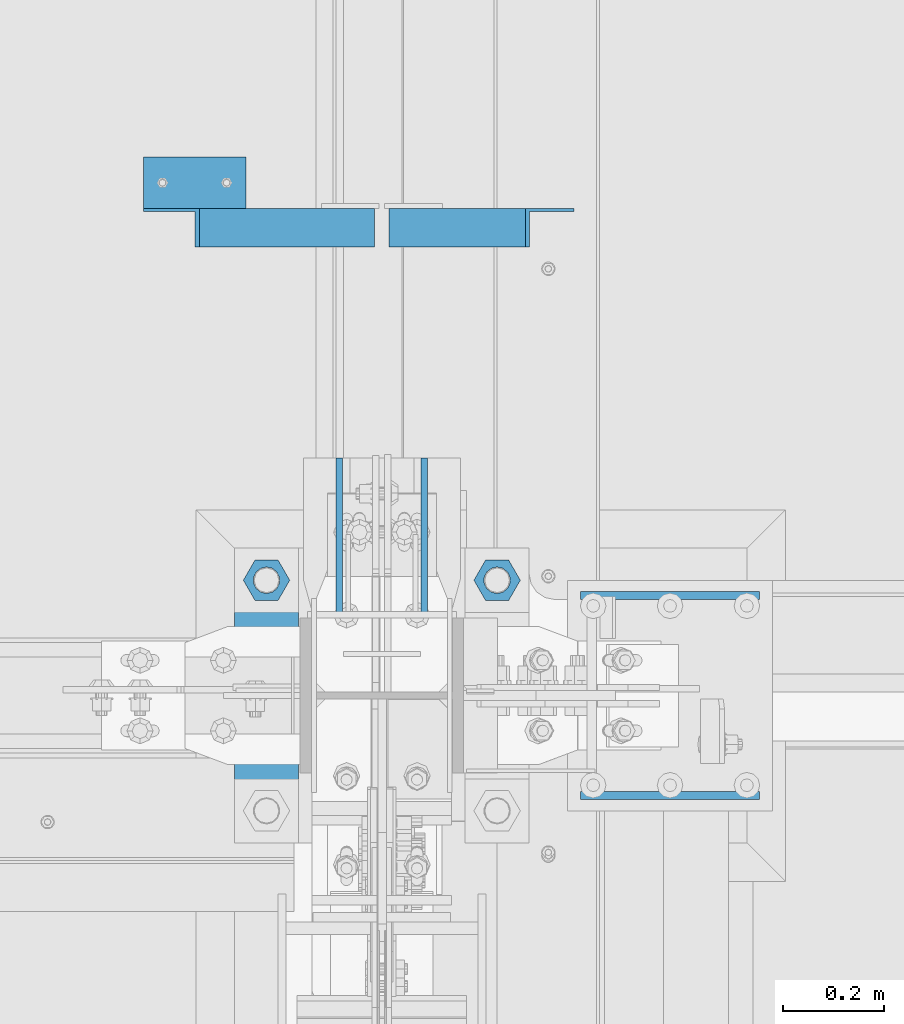
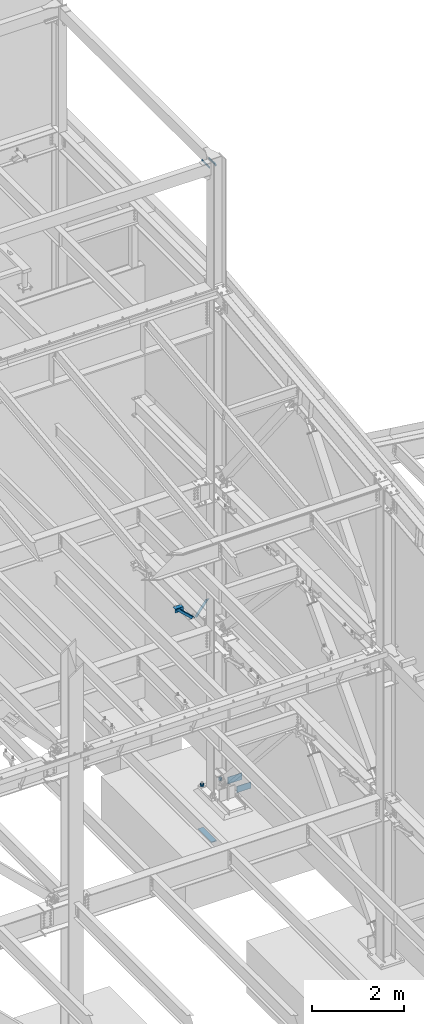
# One storey, part 899 of 1179: 8 beams, 2 members, 7 elements without a shape of their own.
"""IFC2X3 building model written with IfcOpenShell, lengths in millimetres."""

from ifc_helpers import new_model, si_unit, frame, origin_with_axes, place, context, subcontext, project, spatial, faceted_brep, material, type_object, element, aggregate, save


model = new_model("IFC2X3")

# Units and contexts
model_context = context("Model", 3, precision=1e-05, world=origin_with_axes())
body_context = subcontext(model_context, "Body", "Model", "MODEL_VIEW")
ifc_project = project(units=[si_unit("LENGTHUNIT", "METRE", prefix="MILLI"), si_unit("AREAUNIT", "SQUARE_METRE"), si_unit("VOLUMEUNIT", "CUBIC_METRE"), si_unit("MASSUNIT", "GRAM", prefix="KILO"), si_unit("TIMEUNIT", "SECOND"), si_unit("PLANEANGLEUNIT", "RADIAN"), si_unit("SOLIDANGLEUNIT", "STERADIAN"), si_unit("THERMODYNAMICTEMPERATUREUNIT", "DEGREE_CELSIUS"), si_unit("LUMINOUSINTENSITYUNIT", "LUMEN")], contexts=[model_context])

# Site, building, storey
site_placement = place(None, origin_with_axes())
site = spatial("IfcSite", under=ifc_project, at=site_placement, CompositionType="ELEMENT")
building_placement = place(site_placement, origin_with_axes())
building = spatial("IfcBuilding", under=site, at=building_placement, Name="Undefined", CompositionType="ELEMENT")
storey_placement = place(building_placement, origin_with_axes())
storey = spatial("IfcBuildingStorey", under=building, at=storey_placement, Name="Undefined", CompositionType="ELEMENT", Elevation=0.0)

# Assembly, member
assembly_1_placement = place(storey_placement, origin_with_axes())
assembly_1 = element("IfcElementAssembly", 1, at=assembly_1_placement, inside=storey, Name="ANGLE", AssemblyPlace="NOTDEFINED", PredefinedType="RIGID_FRAME")
ifc_material_1 = material(Name="STEEL/A36")
member_type = type_object("IfcMemberType", Name="L3X3X1/4", PredefinedType="NOTDEFINED")
member_1_placement = place(assembly_1_placement, frame((23812.1150890972, 35319.49375, 4162.88757791506), z_axis=(0.0, -1.0, 0.0), x_axis=(0.729484494811633, 0.0, -0.683997347823379)))
member_1 = element("IfcMember", 2, at=member_1_placement, type_object=member_type, material=ifc_material_1, Name="ANGLE", ObjectType="L3X3X1/4", context=body_context, shape_type="Brep", body=[
    faceted_brep([(148.072119708857, 38.1000000000204, -38.0999999999985), (148.072119708857, 38.1000000000204, 38.0999999999985), (623.824460863128, 38.1000000000349, 38.0999999999985), (623.824460863128, 38.1000000000349, -38.0999999999985), (141.299832423247, 31.7500000000182, 38.0999999999985), (623.824460863128, 31.7500000000291, 38.0999999999985), (141.299832423247, 31.7500000000182, -31.75), (623.824460863128, 31.7500000000291, -31.75), (66.8046722815307, -38.1000000000095, -31.75), (623.824460863132, -38.0999999999913, -31.75), (66.8046722815307, -38.1000000000095, -38.0999999999985), (623.824460863132, -38.0999999999913, -38.0999999999985)], [[[0, 1, 2, 3]], [[1, 4, 5, 2]], [[4, 6, 7, 5]], [[6, 8, 9, 7]], [[8, 10, 11, 9]], [[10, 0, 3, 11]], [[5, 7, 9, 11, 3, 2]], [[10, 8, 6, 4, 1, 0]]]),
])
aggregate(assembly_1, [member_1])

assembly_2_placement = place(storey_placement, origin_with_axes())
assembly_2 = element("IfcElementAssembly", 3, at=assembly_2_placement, inside=storey, Name="ANGLE", AssemblyPlace="NOTDEFINED", PredefinedType="RIGID_FRAME")
member_2_placement = place(assembly_2_placement, frame((24352.3014298031, 35319.49375, 3731.6636484264), z_axis=(0.0, -1.0, 0.0), x_axis=(0.614083067285056, 0.0, 0.789241399366365)))
member_2 = element("IfcMember", 4, at=member_2_placement, type_object=member_type, material=ifc_material_1, Name="ANGLE", ObjectType="L3X3X1/4", context=body_context, shape_type="Brep", body=[
    faceted_brep([(0.0, 38.0999999999985, -38.0999999999999), (0.0, 38.0999999999985, 38.0999999999999), (439.713105507173, 38.1000000000386, 38.0999999999985), (439.713105507173, 38.1000000000386, -38.0999999999985), (0.0, 31.75, 38.1000000000004), (444.653834009747, 31.7500000000473, 38.0999999999985), (0.0, 31.75, -31.75), (444.653834009747, 31.7500000000473, -31.75), (0.0, -38.0999999999985, -31.75), (499.001847538042, -38.0999999998749, -31.75), (0.0, -38.0999999999985, -38.0999999999999), (499.001847538042, -38.0999999998749, -38.0999999999985)], [[[0, 1, 2, 3]], [[1, 4, 5, 2]], [[4, 6, 7, 5]], [[6, 8, 9, 7]], [[8, 10, 11, 9]], [[10, 0, 3, 11]], [[5, 7, 9, 11, 3, 2]], [[10, 8, 6, 4, 1, 0]]]),
])
aggregate(assembly_2, [member_2])

# Assembly, beam
assembly_3_placement = place(storey_placement, origin_with_axes())
assembly_3 = element("IfcElementAssembly", 5, at=assembly_3_placement, inside=storey, Name="TEMPLATE", AssemblyPlace="NOTDEFINED", PredefinedType="RIGID_FRAME")
beam_type_1 = type_object("IfcBeamType", PredefinedType="NOTDEFINED")
beam_1_placement = place(assembly_3_placement, frame((24079.1999938965, 34683.7000061035, -1362.075), z_axis=(1.0, 0.0, 0.0), x_axis=(0.0, -1.0, 0.0)))
beam_1 = element("IfcBeam", 6, at=beam_1_placement, type_object=beam_type_1, material=ifc_material_1, Name="SQ WASHER", context=body_context, shape_type="Brep", body=[
    faceted_brep([(0.0, 9.52500000000146, -63.5), (0.0, 9.52500000000146, 63.5), (584.199999999997, 9.52500000000009, 63.5), (584.199999999997, 9.52500000000009, -63.5), (0.0, -9.52500000000146, 63.5), (584.199999999997, -9.52500000000009, 63.5), (0.0, -9.52500000000146, -63.5), (584.199999999997, -9.52500000000009, -63.5)], [[[0, 1, 2, 3]], [[1, 4, 5, 2]], [[4, 6, 7, 5]], [[6, 0, 3, 7]], [[5, 7, 3, 2]], [[6, 4, 1, 0]]]),
])

assembly_4_placement = place(storey_placement, origin_with_axes())
assembly_4 = element("IfcElementAssembly", 7, at=assembly_4_placement, inside=storey, Name="ANGLE", AssemblyPlace="NOTDEFINED", PredefinedType="RIGID_FRAME")
beam_type_2 = type_object("IfcBeamType", Name="L4X4X1/4", PredefinedType="NOTDEFINED")
beam_2_placement = place(assembly_4_placement, frame((23834.8036446584, 35408.39375, 4051.3), z_axis=(0.0, 0.0, -1.0), x_axis=(1.0, 0.0, 0.0)))
beam_2 = element("IfcBeam", 8, at=beam_2_placement, type_object=beam_type_2, material=ifc_material_1, Name="ANGLE", ObjectType="L4X4X1/4", context=body_context, shape_type="Brep", body=[
    faceted_brep([(1.90993887372315e-11, 50.8000000000002, -50.8000000000002), (1.90993887372315e-11, 50.8000000000002, 50.8000000000002), (203.200000000001, 50.7999999999993, 50.8000000000002), (203.200000000001, 50.7999999999993, -50.8000000000002), (0.0, 44.4500000000007, 50.8000000000002), (203.200000000001, 44.4500000000007, 50.8000000000002), (0.0, 44.4500000000007, -44.4499999999998), (203.200000000001, 44.4500000000007, -44.4499999999998), (0.0, -50.7999999999993, -44.4499999999998), (203.200000000001, -50.7999999999993, -44.4499999999998), (-1.81898940354586e-11, -50.7999999999997, -50.8000000000002), (203.200000000001, -50.7999999999993, -50.8000000000002)], [[[0, 1, 2, 3]], [[1, 4, 5, 2]], [[4, 6, 7, 5]], [[6, 8, 9, 7]], [[8, 10, 11, 9]], [[10, 0, 3, 11]], [[5, 7, 9, 11, 3, 2]], [[10, 8, 6, 4, 1, 0]]]),
])
aggregate(assembly_4, [beam_2])

# Assembly, beams
assembly_5_placement = place(storey_placement, origin_with_axes())
assembly_5 = element("IfcElementAssembly", 9, at=assembly_5_placement, inside=storey, Name="COLUMN", AssemblyPlace="NOTDEFINED", PredefinedType="RIGID_FRAME")
beam_type_3 = type_object("IfcBeamType", PredefinedType="NOTDEFINED")
beam_3_placement = place(assembly_5_placement, frame((24391.9375, 34863.0875, 16141.7), z_axis=(0.0, 0.0, 1.0), x_axis=(0.0, -1.0, 0.0)))
beam_3 = element("IfcBeam", 10, at=beam_3_placement, type_object=beam_type_3, material=ifc_material_1, Name="PLATE", context=body_context, shape_type="Brep", body=[
    faceted_brep([(0.0, 6.34999999999854, -19.0499999999993), (0.0, 6.35000000000036, 19.0499999999993), (317.5, 6.34999999999854, 19.0499999999993), (317.5, 6.34999999999854, -19.0499999999993), (0.0, -6.35000000000036, 19.0499999999993), (317.5, -6.34999999999854, 19.0499999999993), (0.0, -6.34999999999854, -19.0499999999993), (317.5, -6.34999999999854, -19.0499999999993)], [[[0, 1, 2, 3]], [[1, 4, 5, 2]], [[4, 6, 7, 5]], [[6, 0, 3, 7]], [[5, 7, 3, 2]], [[6, 4, 1, 0]]]),
])
beam_4_placement = place(assembly_5_placement, frame((24223.6625, 34863.0875, 16141.7), z_axis=(0.0, 0.0, 1.0), x_axis=(0.0, -1.0, 0.0)))
beam_4 = element("IfcBeam", 11, at=beam_4_placement, type_object=beam_type_3, material=ifc_material_1, Name="PLATE", context=body_context, shape_type="Brep", body=[
    faceted_brep([(0.0, 6.34999999999854, -19.0499999999993), (0.0, 6.35000000000036, 19.0499999999993), (317.5, 6.34999999999854, 19.0499999999993), (317.5, 6.34999999999854, -19.0499999999993), (0.0, -6.35000000000036, 19.0499999999993), (317.5, -6.34999999999854, 19.0499999999993), (0.0, -6.34999999999854, -19.0499999999993), (317.5, -6.34999999999854, -19.0499999999993)], [[[0, 1, 2, 3]], [[1, 4, 5, 2]], [[4, 6, 7, 5]], [[6, 0, 3, 7]], [[5, 7, 3, 2]], [[6, 4, 1, 0]]]),
])
aggregate(assembly_5, [beam_3, beam_4])

# Beam
beam_type_4 = type_object("IfcBeamType", Name="2_HEAVY_HEX_NUT", PredefinedType="NOTDEFINED")
beam_5_placement = place(assembly_3_placement, frame((24079.2, 34620.2, -149.225), z_axis=(0.0, -1.0, 0.0), x_axis=(0.0, 0.0, -1.0)))
beam_5 = element("IfcBeam", 12, at=beam_5_placement, type_object=beam_type_4, material=ifc_material_1, Name="NUT", ObjectType="2_HEAVY_HEX_NUT", context=body_context, shape_type="Brep", body=[
    faceted_brep([(0.0, -46.0369987487793, 9.09494701772928e-13), (0.0, -23.0184993743896, -39.869213104248), (50.7999999999993, -23.0184993743896, -39.869213104248), (50.7999999999993, -46.0369987487793, 9.09494701772928e-13), (0.0, 23.0184993743896, -39.869213104248), (50.7999999999993, 23.0184993743896, -39.869213104248), (0.0, 46.0369987487793, -9.09494701772928e-13), (50.7999999999993, 46.0369987487793, -9.09494701772928e-13), (0.0, 23.0184993743896, 39.869213104248), (50.7999999999993, 23.0184993743896, 39.869213104248), (0.0, -23.0184993743896, 39.869213104248), (50.7999999999993, -23.0184993743896, 39.869213104248), (0.0, 0.0, 26.1940002441406), (0.0, 11.3650617044477, 23.5999013092769), (50.7999999999993, 11.3650617044477, 23.5999013092769), (50.7999999999993, 0.0, 26.1940002441406), (0.0, 20.4791109456419, 16.3316083006703), (50.7999999999993, 20.4791109456419, 16.3316083006703), (0.0, 25.5370200498364, 5.82867859874477), (50.7999999999993, 25.5370200498364, 5.82867859874477), (0.0, 25.5370200498364, -5.82867859874477), (50.7999999999993, 25.5370200498364, -5.82867859874477), (0.0, 20.4791109456419, -16.3316083006703), (50.7999999999993, 20.4791109456419, -16.3316083006703), (0.0, 11.365061704455, -23.5999013092769), (50.7999999999993, 11.365061704455, -23.5999013092769), (0.0, 0.0, -26.1940002441406), (50.7999999999993, 0.0, -26.1940002441406), (0.0, -11.3650617044477, -23.5999013092769), (50.7999999999993, -11.3650617044477, -23.5999013092769), (0.0, -20.4791109456419, -16.3316083006703), (50.7999999999993, -20.4791109456419, -16.3316083006703), (0.0, -25.5370200498364, -5.82867859874477), (50.7999999999993, -25.5370200498364, -5.82867859874477), (0.0, -25.5370200498364, 5.82867859874477), (50.7999999999993, -25.5370200498364, 5.82867859874477), (0.0, -20.4791109456419, 16.3316083006703), (50.7999999999993, -20.4791109456419, 16.3316083006703), (0.0, -11.365061704455, 23.5999013092769), (50.7999999999993, -11.365061704455, 23.5999013092769)], [[[0, 1, 2, 3]], [[1, 4, 5, 2]], [[4, 6, 7, 5]], [[6, 8, 9, 7]], [[8, 10, 11, 9]], [[10, 0, 3, 11]], [[12, 13, 14, 15]], [[13, 16, 17, 14]], [[16, 18, 19, 17]], [[18, 20, 21, 19]], [[20, 22, 23, 21]], [[22, 24, 25, 23]], [[24, 26, 27, 25]], [[26, 28, 29, 27]], [[28, 30, 31, 29]], [[30, 32, 33, 31]], [[32, 34, 35, 33]], [[34, 36, 37, 35]], [[36, 38, 39, 37]], [[38, 12, 15, 39]], [[5, 7, 9, 11, 3, 2], [17, 19, 21, 23, 25, 27, 29, 31, 33, 35, 37, 39, 15, 14]], [[10, 8, 6, 4, 1, 0], [38, 36, 34, 32, 30, 28, 26, 24, 22, 20, 18, 16, 13, 12]]]),
])

beam_6_placement = place(assembly_3_placement, frame((24536.4, 34620.2, -149.225), z_axis=(0.0, 1.0, 0.0), x_axis=(0.0, 0.0, -1.0)))
beam_6 = element("IfcBeam", 13, at=beam_6_placement, type_object=beam_type_4, material=ifc_material_1, Name="NUT", ObjectType="2_HEAVY_HEX_NUT", context=body_context, shape_type="Brep", body=[
    faceted_brep([(0.0, -46.0369987487793, 9.09494701772928e-13), (0.0, -23.0184993743896, -39.869213104248), (50.7999999999993, -23.0184993743896, -39.869213104248), (50.7999999999993, -46.0369987487793, 9.09494701772928e-13), (0.0, 23.0184993743896, -39.869213104248), (50.7999999999993, 23.0184993743896, -39.869213104248), (0.0, 46.0369987487793, -9.09494701772928e-13), (50.7999999999993, 46.0369987487793, -9.09494701772928e-13), (0.0, 23.0184993743896, 39.869213104248), (50.7999999999993, 23.0184993743896, 39.869213104248), (0.0, -23.0184993743896, 39.869213104248), (50.7999999999993, -23.0184993743896, 39.869213104248), (0.0, 0.0, 26.1940002441406), (0.0, 11.3650617044477, 23.5999013092769), (50.7999999999993, 11.3650617044477, 23.5999013092769), (50.7999999999993, 0.0, 26.1940002441406), (0.0, 20.4791109456419, 16.3316083006703), (50.7999999999993, 20.4791109456419, 16.3316083006703), (0.0, 25.5370200498364, 5.82867859874477), (50.7999999999993, 25.5370200498364, 5.82867859874477), (0.0, 25.5370200498364, -5.82867859874477), (50.7999999999993, 25.5370200498364, -5.82867859874477), (0.0, 20.4791109456419, -16.3316083006703), (50.7999999999993, 20.4791109456419, -16.3316083006703), (0.0, 11.365061704455, -23.5999013092769), (50.7999999999993, 11.365061704455, -23.5999013092769), (0.0, 0.0, -26.1940002441406), (50.7999999999993, 0.0, -26.1940002441406), (0.0, -11.3650617044477, -23.5999013092769), (50.7999999999993, -11.3650617044477, -23.5999013092769), (0.0, -20.4791109456419, -16.3316083006703), (50.7999999999993, -20.4791109456419, -16.3316083006703), (0.0, -25.5370200498364, -5.82867859874477), (50.7999999999993, -25.5370200498364, -5.82867859874477), (0.0, -25.5370200498364, 5.82867859874477), (50.7999999999993, -25.5370200498364, 5.82867859874477), (0.0, -20.4791109456419, 16.3316083006703), (50.7999999999993, -20.4791109456419, 16.3316083006703), (0.0, -11.365061704455, 23.5999013092769), (50.7999999999993, -11.365061704455, 23.5999013092769)], [[[0, 1, 2, 3]], [[1, 4, 5, 2]], [[4, 6, 7, 5]], [[6, 8, 9, 7]], [[8, 10, 11, 9]], [[10, 0, 3, 11]], [[12, 13, 14, 15]], [[13, 16, 17, 14]], [[16, 18, 19, 17]], [[18, 20, 21, 19]], [[20, 22, 23, 21]], [[22, 24, 25, 23]], [[24, 26, 27, 25]], [[26, 28, 29, 27]], [[28, 30, 31, 29]], [[30, 32, 33, 31]], [[32, 34, 35, 33]], [[34, 36, 37, 35]], [[36, 38, 39, 37]], [[38, 12, 15, 39]], [[5, 7, 9, 11, 3, 2], [17, 19, 21, 23, 25, 27, 29, 31, 33, 35, 37, 39, 15, 14]], [[10, 8, 6, 4, 1, 0], [38, 36, 34, 32, 30, 28, 26, 24, 22, 20, 18, 16, 13, 12]]]),
])

aggregate(assembly_3, [beam_5, beam_6, beam_1])

# Assembly, beam
assembly_6_placement = place(storey_placement, origin_with_axes())
assembly_6 = element("IfcElementAssembly", 14, at=assembly_6_placement, inside=storey, Name="PLATE", AssemblyPlace="NOTDEFINED", PredefinedType="RIGID_FRAME")
ifc_material_2 = material(Name="STEEL/A572-GR.50")
beam_type_5 = type_object("IfcBeamType", PredefinedType="NOTDEFINED")
beam_7_placement = place(assembly_6_placement, frame((24701.5000006933, 34590.037494071, -266.700006103515), z_axis=(0.0, 0.0, 1.0), x_axis=(1.0, 0.0, 0.0)))
beam_7 = element("IfcBeam", 15, at=beam_7_placement, type_object=beam_type_5, material=ifc_material_2, Name="PLATE", context=body_context, shape_type="Brep", body=[
    faceted_brep([(355.599999999999, 7.9375, -73.025), (355.599999999999, -7.9375, -88.9), (0.0, -7.9375, -88.9), (0.0, 7.9375, -73.025), (0.0, 7.9375, 88.9), (355.599999999999, 7.9375, 88.9), (0.0, -7.9375, 88.9), (355.599999999999, -7.9375, 88.9)], [[[0, 1, 2, 3]], [[4, 5, 0, 3]], [[4, 6, 7, 5]], [[6, 2, 1, 7]], [[5, 7, 1, 0]], [[6, 4, 3, 2]]]),
])
aggregate(assembly_6, [beam_7])

assembly_7_placement = place(storey_placement, origin_with_axes())
assembly_7 = element("IfcElementAssembly", 16, at=assembly_7_placement, inside=storey, Name="PLATE", AssemblyPlace="NOTDEFINED", PredefinedType="RIGID_FRAME")
beam_8_placement = place(assembly_7_placement, frame((24701.5000006933, 34193.1625058689, -266.700006103515), z_axis=(0.0, 0.0, 1.0), x_axis=(1.0, 0.0, 0.0)))
beam_8 = element("IfcBeam", 17, at=beam_8_placement, type_object=beam_type_5, material=ifc_material_2, Name="PLATE", context=body_context, shape_type="Brep", body=[
    faceted_brep([(355.599999999999, 7.9375, -88.9), (355.599999999999, -7.9375, -73.025), (0.0, -7.9375, -73.025), (0.0, 7.9375, -88.9), (0.0, 7.9375, 88.9), (355.599999999999, 7.9375, 88.9), (0.0, -7.9375, 88.9), (355.599999999999, -7.9375, 88.9)], [[[0, 1, 2, 3]], [[3, 4, 5, 0]], [[4, 6, 7, 5]], [[7, 6, 2, 1]], [[5, 7, 1, 0]], [[6, 4, 3, 2]]]),
])
aggregate(assembly_7, [beam_8])

save(model, "model.ifc")
